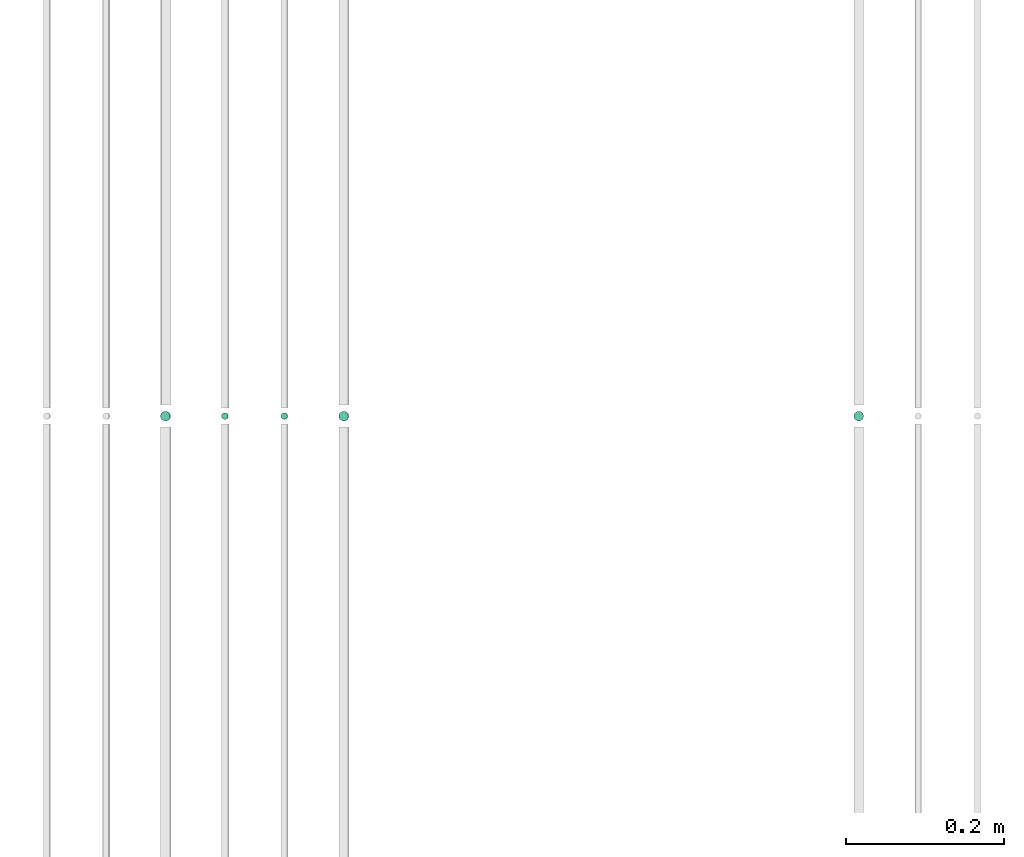
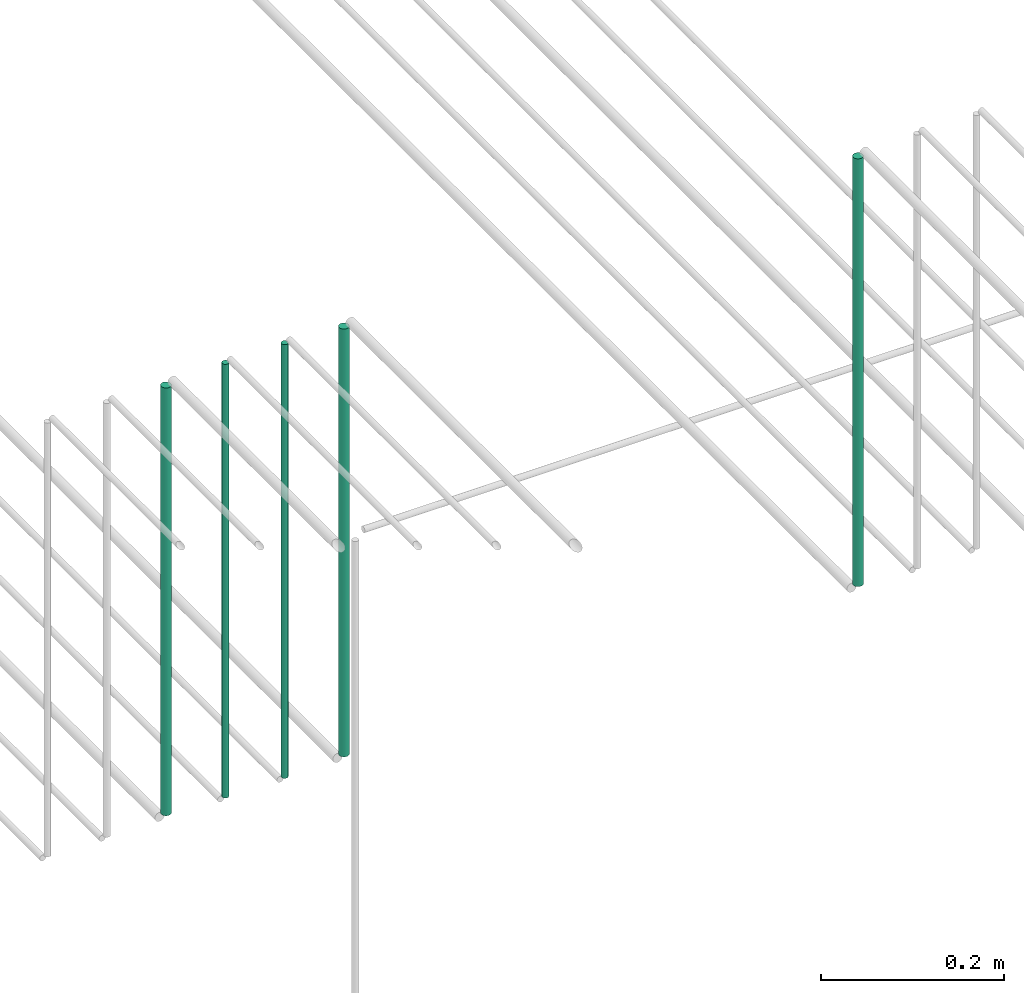
# One storey, part 176 of 331: 5 flow segments.
"""IFC2X3 building model written with IfcOpenShell, lengths in millimetres."""

from ifc_helpers import new_model, entity, si_unit, converted_unit, derived_unit, direction, frame, frame_2d, origin, origin_2d_with_axis, place, context, subcontext, project, spatial, circle, extrude, type_object, element, save


model = new_model("IFC2X3")

# Units and contexts
model_context = context("Model", 3, precision=0.01, world=origin(), true_north=direction((6.12303176911189e-17, 1.0)))
body_context = subcontext(model_context, "Body", "Model", "MODEL_VIEW")
ifc_project = project(units=[si_unit("LENGTHUNIT", "METRE", prefix="MILLI"), si_unit("AREAUNIT", "SQUARE_METRE"), si_unit("VOLUMEUNIT", "CUBIC_METRE"), converted_unit("PLANEANGLEUNIT", "DEGREE", entity("IfcRatioMeasure", 0.0174532925199433), si_unit("PLANEANGLEUNIT", "RADIAN"), dimensions=[0, 0, 0, 0, 0, 0, 0]), si_unit("MASSUNIT", "GRAM", prefix="KILO"), derived_unit("MASSDENSITYUNIT", [(si_unit("MASSUNIT", "GRAM", prefix="KILO"), 1), (si_unit("LENGTHUNIT", "METRE"), -3)]), derived_unit("MOMENTOFINERTIAUNIT", [(si_unit("LENGTHUNIT", "METRE"), 4)]), si_unit("TIMEUNIT", "SECOND"), si_unit("FREQUENCYUNIT", "HERTZ"), si_unit("THERMODYNAMICTEMPERATUREUNIT", "DEGREE_CELSIUS"), derived_unit("THERMALTRANSMITTANCEUNIT", [(si_unit("MASSUNIT", "GRAM", prefix="KILO"), 1), (si_unit("THERMODYNAMICTEMPERATUREUNIT", "KELVIN"), -1), (si_unit("TIMEUNIT", "SECOND"), -3)]), derived_unit("VOLUMETRICFLOWRATEUNIT", [(si_unit("LENGTHUNIT", "METRE"), 3), (si_unit("TIMEUNIT", "SECOND"), -1)]), derived_unit("MASSFLOWRATEUNIT", [(si_unit("MASSUNIT", "GRAM", prefix="KILO"), 1), (si_unit("TIMEUNIT", "SECOND"), -1)]), derived_unit("ROTATIONALFREQUENCYUNIT", [(si_unit("TIMEUNIT", "SECOND"), -1)]), si_unit("ELECTRICCURRENTUNIT", "AMPERE"), si_unit("ELECTRICVOLTAGEUNIT", "VOLT"), si_unit("POWERUNIT", "WATT"), si_unit("FORCEUNIT", "NEWTON", prefix="KILO"), si_unit("ILLUMINANCEUNIT", "LUX"), si_unit("LUMINOUSFLUXUNIT", "LUMEN"), si_unit("LUMINOUSINTENSITYUNIT", "CANDELA"), derived_unit("USERDEFINED", [(si_unit("MASSUNIT", "GRAM", prefix="KILO"), -1), (si_unit("LENGTHUNIT", "METRE"), -2), (si_unit("TIMEUNIT", "SECOND"), 3), (si_unit("LUMINOUSFLUXUNIT", "LUMEN"), 1)]), derived_unit("LINEARVELOCITYUNIT", [(si_unit("LENGTHUNIT", "METRE"), 1), (si_unit("TIMEUNIT", "SECOND"), -1)]), si_unit("PRESSUREUNIT", "PASCAL"), derived_unit("USERDEFINED", [(si_unit("LENGTHUNIT", "METRE"), -2), (si_unit("MASSUNIT", "GRAM", prefix="KILO"), 1), (si_unit("TIMEUNIT", "SECOND"), -2)]), derived_unit("LINEARFORCEUNIT", [(si_unit("MASSUNIT", "GRAM", prefix="KILO"), 1), (si_unit("LENGTHUNIT", "METRE"), 1), (si_unit("TIMEUNIT", "SECOND"), -2), (si_unit("LENGTHUNIT", "METRE"), -1)]), derived_unit("PLANARFORCEUNIT", [(si_unit("MASSUNIT", "GRAM", prefix="KILO"), 1), (si_unit("LENGTHUNIT", "METRE"), 1), (si_unit("TIMEUNIT", "SECOND"), -2), (si_unit("LENGTHUNIT", "METRE"), -2)])], contexts=[model_context])

# Site, building, storey
site_placement = place(None, frame((0.0, -0.00077364408347762, 0.0)))
site = spatial("IfcSite", under=ifc_project, at=site_placement, CompositionType="ELEMENT")
building_placement = place(site_placement, origin())
building = spatial("IfcBuilding", under=site, at=building_placement, CompositionType="ELEMENT")
storey_placement = place(building_placement, origin())
storey = spatial("IfcBuildingStorey", under=building, at=storey_placement, CompositionType="ELEMENT", Elevation=0.0)

# Flow segments
pipe_segment_type = type_object("IfcPipeSegmentType", PredefinedType="NOTDEFINED")
flow_segment_1_placement = place(storey_placement, frame((43612.4468045266, 5636.02529159143, 18464.0)))
element("IfcFlowSegment", 1, at=flow_segment_1_placement, inside=storey, type_object=pipe_segment_type, context=body_context, shape_type="SweptSolid", body=[
    extrude(circle(Radius=6.0, at=origin_2d_with_axis()), frame((7.59527223591454, 7.59527223591562, 0.0), z_axis=(0.0, 0.0, 1.0), x_axis=(-1.0, 0.0, 0.0)), (0.0, 0.0, 1.0), 572.000000000002),
])
flow_segment_2_placement = place(storey_placement, frame((43689.4468045266, 5638.02529159143, 18460.0)))
element("IfcFlowSegment", 2, at=flow_segment_2_placement, inside=storey, type_object=pipe_segment_type, context=body_context, shape_type="SweptSolid", body=[
    extrude(circle(Radius=4.0, at=origin_2d_with_axis()), frame((5.59527223591499, 5.59527223591607, 0.0), z_axis=(0.0, 0.0, 1.0), x_axis=(-1.0, 0.0, 0.0)), (0.0, 0.0, 1.0), 580.000000000015),
])
flow_segment_3_placement = place(storey_placement, frame((43764.4468045266, 5638.02529159143, 18460.0)))
element("IfcFlowSegment", 3, at=flow_segment_3_placement, inside=storey, type_object=pipe_segment_type, context=body_context, shape_type="SweptSolid", body=[
    extrude(circle(Radius=4.0, at=frame_2d((0.0, -1.08286712929839e-12), x_axis=(1.0, 0.0))), frame((5.59527223591499, 5.59527223591499, 0.0), z_axis=(0.0, 0.0, 1.0), x_axis=(-1.0, 0.0, 0.0)), (0.0, 0.0, 1.0), 580.0),
])
for number, where in (
    (4, (43837.4468045266, 5636.02529159144, 18464.0)),
    (5, (44487.5706481368, 5636.02529159144, 18464.0)),
):
    element("IfcFlowSegment", number, at=place(storey_placement, frame(where)), inside=storey, type_object=pipe_segment_type, context=body_context, shape_type="SweptSolid", body=[
        extrude(circle(Radius=6.0, at=origin_2d_with_axis()), frame((7.59527223591454, 7.59527223591562, 0.0), z_axis=(0.0, 0.0, 1.0), x_axis=(-1.0, 0.0, 0.0)), (0.0, 0.0, 1.0), 572.000000000011),
    ])

save(model, "model.ifc")
